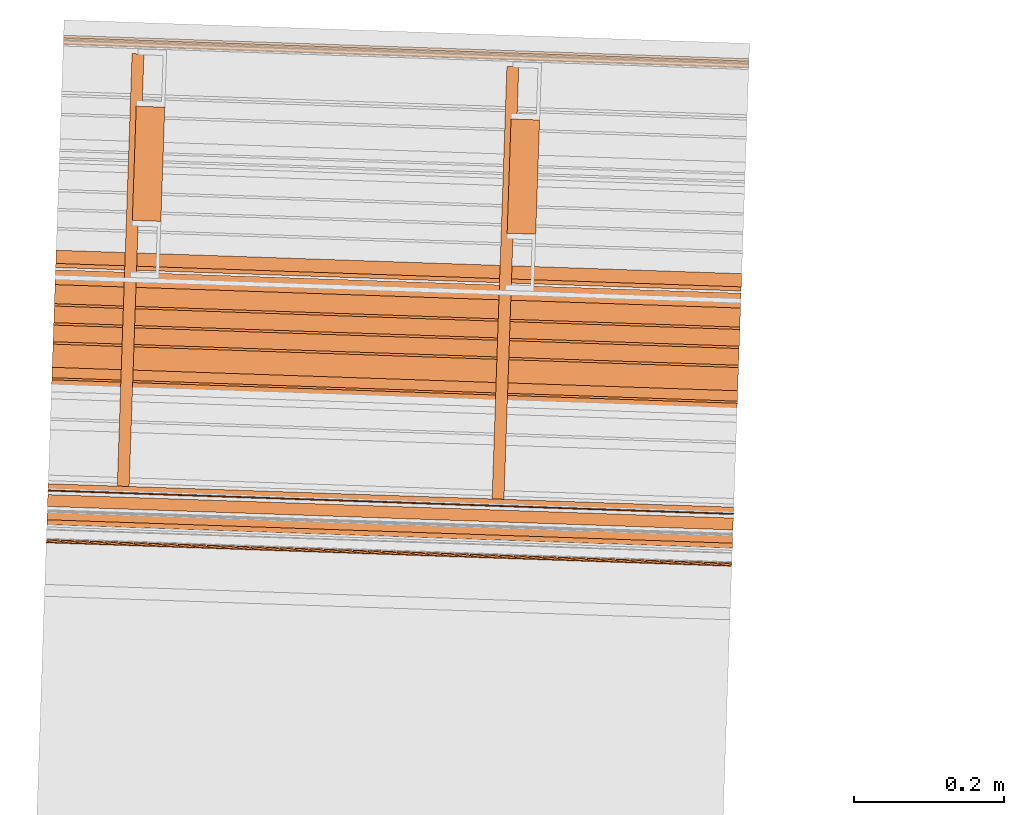
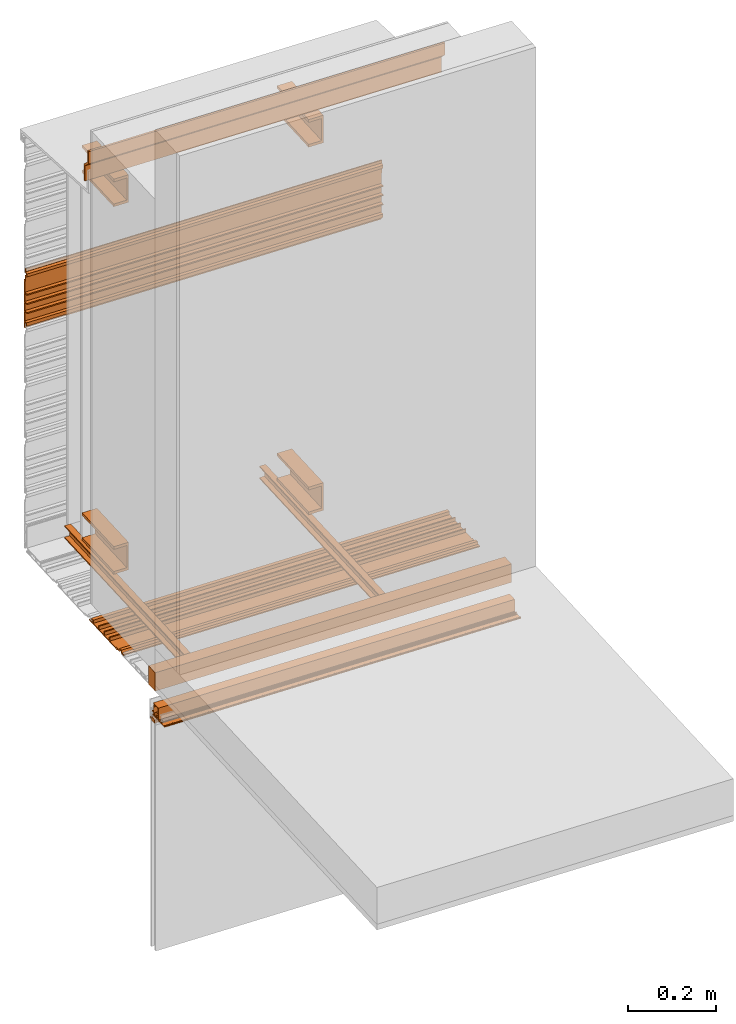
# One storey, part 4 of 7: 13 proxies.
"""IFC2X3 building model written with IfcOpenShell, lengths in feet."""

from ifc_helpers import new_model, entity, si_unit, converted_unit, derived_unit, direction, frame, frame_2d, origin, place, context, subcontext, project, spatial, polyline, circle_curve, parameter, trimmed, segment, composite_curve, rectangle, outline, extrude, source, transform, mapped, material, type_object, type_shapes, element, save


model = new_model("IFC2X3")

# Units and contexts
model_context = context("Model", 3, precision=0.0001, world=origin(), true_north=direction((6.12303176911189e-17, 1.0)))
context_of_model = context(None, 3, precision=0.0001, world=origin(), true_north=direction((6.12303176911189e-17, 1.0)))
body_context = subcontext(model_context, "Body", "Model", "MODEL_VIEW")
ifc_project = project(units=[converted_unit("LENGTHUNIT", "FOOT", entity("IfcRatioMeasure", 0.3048), si_unit("LENGTHUNIT", "METRE"), dimensions=[1, 0, 0, 0, 0, 0, 0]), converted_unit("AREAUNIT", "SQUARE FOOT", entity("IfcRatioMeasure", 0.09290304), si_unit("AREAUNIT", "SQUARE_METRE"), dimensions=[2, 0, 0, 0, 0, 0, 0]), converted_unit("VOLUMEUNIT", "CUBIC FOOT", entity("IfcRatioMeasure", 0.028316846592), si_unit("VOLUMEUNIT", "CUBIC_METRE"), dimensions=[3, 0, 0, 0, 0, 0, 0]), converted_unit("PLANEANGLEUNIT", "DEGREE", entity("IfcRatioMeasure", 0.0174532925199433), si_unit("PLANEANGLEUNIT", "RADIAN"), dimensions=[0, 0, 0, 0, 0, 0, 0]), si_unit("MASSUNIT", "GRAM", prefix="KILO"), derived_unit("MASSDENSITYUNIT", [(si_unit("MASSUNIT", "GRAM", prefix="KILO"), 1), (si_unit("LENGTHUNIT", "METRE"), -3)]), si_unit("TIMEUNIT", "SECOND"), si_unit("FREQUENCYUNIT", "HERTZ"), si_unit("THERMODYNAMICTEMPERATUREUNIT", "DEGREE_CELSIUS"), derived_unit("THERMALTRANSMITTANCEUNIT", [(si_unit("MASSUNIT", "GRAM", prefix="KILO"), 1), (si_unit("THERMODYNAMICTEMPERATUREUNIT", "KELVIN"), -1), (si_unit("TIMEUNIT", "SECOND"), -3)]), derived_unit("VOLUMETRICFLOWRATEUNIT", [(si_unit("LENGTHUNIT", "METRE"), 3), (si_unit("TIMEUNIT", "SECOND"), -1)]), si_unit("ELECTRICCURRENTUNIT", "AMPERE"), si_unit("ELECTRICVOLTAGEUNIT", "VOLT"), si_unit("POWERUNIT", "WATT"), si_unit("FORCEUNIT", "NEWTON"), si_unit("ILLUMINANCEUNIT", "LUX"), si_unit("LUMINOUSFLUXUNIT", "LUMEN"), si_unit("LUMINOUSINTENSITYUNIT", "CANDELA"), derived_unit("USERDEFINED", [(si_unit("MASSUNIT", "GRAM", prefix="KILO"), -1), (si_unit("LENGTHUNIT", "METRE"), -2), (si_unit("TIMEUNIT", "SECOND"), 3), (si_unit("LUMINOUSFLUXUNIT", "LUMEN"), 1)]), derived_unit("LINEARVELOCITYUNIT", [(si_unit("LENGTHUNIT", "METRE"), 1), (si_unit("TIMEUNIT", "SECOND"), -1)]), si_unit("PRESSUREUNIT", "PASCAL"), derived_unit("USERDEFINED", [(si_unit("LENGTHUNIT", "METRE"), -2), (si_unit("MASSUNIT", "GRAM", prefix="KILO"), 1), (si_unit("TIMEUNIT", "SECOND"), -2)])], contexts=[model_context, context_of_model])

# Site, building, storey
site_placement = place(None, origin())
site = spatial("IfcSite", under=ifc_project, at=site_placement, CompositionType="ELEMENT")
building_placement = place(site_placement, origin())
building = spatial("IfcBuilding", under=site, at=building_placement, CompositionType="ELEMENT")
storey_placement = place(building_placement, origin())
storey = spatial("IfcBuildingStorey", under=building, at=storey_placement, Name="Level 1", CompositionType="ELEMENT", Elevation=0.0)

# Proxies
ifc_material_1 = material(Name="IfcSurfaceStyle #179")
building_element_proxy_type_1 = type_object("IfcBuildingElementProxyType", Name="Metal support for window frame001", PredefinedType="NOTDEFINED", material=ifc_material_1)
shared_shape_1 = source(origin(), body_context, "Body", "SweptSolid", [
    extrude(rectangle(XDim=3.0, YDim=0.107278015091847, at=frame_2d((-6.99440505513849e-15, -2.42861286636753e-16), x_axis=(1.0, 0.0))), frame((111.216846057744, -50.6154050021282, 9.70833333333332), z_axis=(0.0, 0.0, 1.0), x_axis=(-0.999414947916634, 0.0342017818364937, 0.0)), (0.0, 0.0, 1.0), 0.166666666666668),
])
type_shapes(building_element_proxy_type_1, [shared_shape_1])
proxy_1_placement = place(storey_placement, origin())
element("IfcBuildingElementProxy", 1, at=proxy_1_placement, inside=storey, type_object=building_element_proxy_type_1, material=ifc_material_1, ObjectType="Metal support for window frame001", context=body_context, shape_type="MappedRepresentation", body=[
    mapped(shared_shape_1, transform((0.0, 0.0, 0.0), scale=1.0)),
])
ifc_material_2 = material(Name="LIGHT GAUGE METAL STUDS AND/OR FURRING")
building_element_proxy_type_2 = type_object("IfcBuildingElementProxyType", Name="Stud 004", PredefinedType="NOTDEFINED", material=ifc_material_2)
shared_shape_2 = source(origin(), body_context, "Body", "SweptSolid", [
    extrude(outline(polyline([(-0.0286458333333562, -0.0572916666666679), (0.0234374999999827, -0.0572916666666679), (0.0234374999999827, -0.046875), (-0.0182291666666801, -0.046875), (-0.0182291666666801, 0.046875), (0.0234374999999827, 0.046875), (0.0234374999999827, 0.0572916666666661), (-0.0286458333333562, 0.0572916666666661), (-0.0286458333333562, -0.0572916666666679)])), frame((110.044847585689, -50.5216266933335, 9.81770833333333), z_axis=(0.0342017818365511, 0.999414947916632, 0.0), x_axis=(-0.999414947916632, 0.0342017818365511, 0.0)), (0.0, 0.0, 1.0), 1.89272198512796),
])
type_shapes(building_element_proxy_type_2, [shared_shape_2])
proxy_2_placement = place(storey_placement, origin())
element("IfcBuildingElementProxy", 2, at=proxy_2_placement, inside=storey, type_object=building_element_proxy_type_2, material=ifc_material_2, Name="Stud 004:Stud 004", ObjectType="Stud 004", context=body_context, shape_type="MappedRepresentation", body=[
    mapped(shared_shape_2, transform((0.0, 0.0, 0.0), scale=1.0)),
])
building_element_proxy_type_3 = type_object("IfcBuildingElementProxyType", Name="Stud 003", PredefinedType="NOTDEFINED", material=ifc_material_2)
shared_shape_3 = source(origin(), body_context, "Body", "SweptSolid", [
    extrude(outline(polyline([(-0.0286458333333278, -0.0572916666666679), (0.023437500000025, -0.0572916666666679), (0.023437500000025, -0.046875), (-0.0182291666666514, -0.046875), (-0.0182291666666514, 0.046875), (0.023437500000025, 0.046875), (0.023437500000025, 0.0572916666666661), (-0.0286458333333278, 0.0572916666666661), (-0.0286458333333278, -0.0572916666666679)])), frame((111.684307802088, -50.5777319784982, 9.81770833333333), z_axis=(0.0342017818364056, 0.999414947916637, 0.0), x_axis=(-0.999414947916637, 0.0342017818364056, 0.0)), (0.0, 0.0, 1.0), 1.89272198512795),
])
type_shapes(building_element_proxy_type_3, [shared_shape_3])
proxy_3_placement = place(storey_placement, origin())
element("IfcBuildingElementProxy", 3, at=proxy_3_placement, inside=storey, type_object=building_element_proxy_type_3, material=ifc_material_2, Name="Stud 003:Stud 003", ObjectType="Stud 003", context=body_context, shape_type="MappedRepresentation", body=[
    mapped(shared_shape_3, transform((0.0, 0.0, 0.0), scale=1.0)),
])
ifc_material_3 = material(Name="METAL STUDS")
building_element_proxy_type_4 = type_object("IfcBuildingElementProxyType", Name="Metal stud 014", PredefinedType="NOTDEFINED", material=ifc_material_3)
shared_shape_4 = source(origin(), body_context, "Body", "SweptSolid", [
    extrude(outline(polyline([(-0.0661909448818519, -0.125), (0.0588090551181219, -0.125), (0.0588090551181219, -0.100393700787402), (-0.0514271653543063, -0.100393700787402), (-0.0514271653543063, 0.100393700787404), (0.0588090551181219, 0.100393700787404), (0.0588090551181219, 0.125000000000002), (-0.0661909448818519, 0.125000000000002), (-0.0661909448818519, -0.125)])), frame((110.146020542697, -49.3608525569486, 10.0), z_axis=(0.0342017818366075, 0.99941494791663, 0.0), x_axis=(-0.99941494791663, 0.0342017818366075, 0.0)), (0.0, 0.0, 1.0), 0.500000000000002),
])
type_shapes(building_element_proxy_type_4, [shared_shape_4])
proxy_4_placement = place(storey_placement, origin())
element("IfcBuildingElementProxy", 4, at=proxy_4_placement, inside=storey, type_object=building_element_proxy_type_4, material=ifc_material_3, Name="Metal stud 014:Metal stud 014", ObjectType="Metal stud 014", context=body_context, shape_type="MappedRepresentation", body=[
    mapped(shared_shape_4, transform((0.0, 0.0, 0.0), scale=1.0)),
])
building_element_proxy_type_5 = type_object("IfcBuildingElementProxyType", Name="Metal stud 011", PredefinedType="NOTDEFINED", material=ifc_material_3)
shared_shape_5 = source(origin(), body_context, "Body", "SweptSolid", [
    extrude(outline(polyline([(-0.0661909448818519, -0.125), (0.0588090551181219, -0.125), (0.0588090551181219, -0.1003937007874), (-0.0514271653543063, -0.1003937007874), (-0.0514271653543063, 0.1003937007874), (0.0588090551181219, 0.1003937007874), (0.0588090551181219, 0.125), (-0.0661909448818519, 0.125), (-0.0661909448818519, -0.125)])), frame((110.146020542697, -49.3608525569486, 13.3333333333333), z_axis=(0.0342017818366075, 0.99941494791663, 0.0), x_axis=(-0.99941494791663, 0.0342017818366075, 0.0)), (0.0, 0.0, 1.0), 0.500000000000002),
])
type_shapes(building_element_proxy_type_5, [shared_shape_5])
proxy_5_placement = place(storey_placement, origin())
element("IfcBuildingElementProxy", 5, at=proxy_5_placement, inside=storey, type_object=building_element_proxy_type_5, material=ifc_material_3, Name="Metal stud 011:Metal stud 011", ObjectType="Metal stud 011", context=body_context, shape_type="MappedRepresentation", body=[
    mapped(shared_shape_5, transform((0.0, 0.0, 0.0), scale=1.0)),
])
building_element_proxy_type_6 = type_object("IfcBuildingElementProxyType", Name="Metal stud 013", PredefinedType="NOTDEFINED", material=ifc_material_3)
shared_shape_6 = source(origin(), body_context, "Body", "SweptSolid", [
    extrude(outline(polyline([(-0.0661909448818803, -0.125), (0.0588090551181075, -0.125), (0.0588090551181075, -0.1003937007874), (-0.0514271653543347, -0.1003937007874), (-0.0514271653543347, 0.1003937007874), (0.0588090551181075, 0.1003937007874), (0.0588090551181075, 0.125), (-0.0661909448818803, 0.125), (-0.0661909448818803, -0.125)])), frame((111.785480759096, -49.4169578421136, 13.3333333333333), z_axis=(0.0342017818365468, 0.999414947916633, 0.0), x_axis=(-0.999414947916633, 0.0342017818365468, 0.0)), (0.0, 0.0, 1.0), 0.500000000000001),
])
type_shapes(building_element_proxy_type_6, [shared_shape_6])
proxy_6_placement = place(storey_placement, origin())
element("IfcBuildingElementProxy", 6, at=proxy_6_placement, inside=storey, type_object=building_element_proxy_type_6, material=ifc_material_3, Name="Metal stud 013:Metal stud 013", ObjectType="Metal stud 013", context=body_context, shape_type="MappedRepresentation", body=[
    mapped(shared_shape_6, transform((0.0, 0.0, 0.0), scale=1.0)),
])
building_element_proxy_type_7 = type_object("IfcBuildingElementProxyType", Name="Metal stud 012", PredefinedType="NOTDEFINED", material=ifc_material_3)
shared_shape_7 = source(origin(), body_context, "Body", "SweptSolid", [
    extrude(outline(polyline([(-0.0661909448818803, -0.125), (0.0588090551181075, -0.125), (0.0588090551181075, -0.100393700787402), (-0.0514271653543347, -0.100393700787402), (-0.0514271653543347, 0.100393700787404), (0.0588090551181075, 0.100393700787404), (0.0588090551181075, 0.125000000000002), (-0.0661909448818803, 0.125000000000002), (-0.0661909448818803, -0.125)])), frame((111.785480759096, -49.4169578421136, 10.0), z_axis=(0.0342017818365468, 0.999414947916633, 0.0), x_axis=(-0.999414947916633, 0.0342017818365468, 0.0)), (0.0, 0.0, 1.0), 0.500000000000001),
])
type_shapes(building_element_proxy_type_7, [shared_shape_7])
proxy_7_placement = place(storey_placement, origin())
element("IfcBuildingElementProxy", 7, at=proxy_7_placement, inside=storey, type_object=building_element_proxy_type_7, material=ifc_material_3, Name="Metal stud 012:Metal stud 012", ObjectType="Metal stud 012", context=body_context, shape_type="MappedRepresentation", body=[
    mapped(shared_shape_7, transform((0.0, 0.0, 0.0), scale=1.0)),
])
ifc_material_4 = material()
building_element_proxy_type_8 = type_object("IfcBuildingElementProxyType", Name="Flashing 003", PredefinedType="NOTDEFINED", material=ifc_material_4)
shared_shape_8 = source(origin(), body_context, "Body", "SweptSolid", [
    extrude(outline(polyline([(-0.0371589137820224, 0.0154669259900354), (-0.135772181632417, -0.0923404467542823), (-0.122552267089255, -0.104432931160668), (-0.0292661571907254, -0.00244938836847988), (0.0490662805214159, -0.0024493883946275), (0.123864814921589, 0.0793229091327372), (0.110644900349842, 0.0914153935652706), (0.0411735239015335, 0.0154669259900354), (-0.0371589137820224, 0.0154669259900354)])), frame((109.753215664138, -49.5269849138619, 13.807758480938), z_axis=(-0.999414947916625, 0.0342017818367569, 0.0), x_axis=(-0.025236475786405, -0.737438512825177, 0.674942634667624)), (0.0, 0.0, -1.0), 3.0),
])
type_shapes(building_element_proxy_type_8, [shared_shape_8])
proxy_8_placement = place(storey_placement, origin())
element("IfcBuildingElementProxy", 8, at=proxy_8_placement, inside=storey, type_object=building_element_proxy_type_8, material=ifc_material_4, Name="Flashing 003:Flashing 003", ObjectType="Flashing 003", context=body_context, shape_type="MappedRepresentation", body=[
    mapped(shared_shape_8, transform((0.0, 0.0, 0.0), scale=1.0)),
])
ifc_material_5 = material(Name="Window frame")
building_element_proxy_type_9 = type_object("IfcBuildingElementProxyType", Name="Window frame 017", PredefinedType="NOTDEFINED", material=ifc_material_5)
shared_shape_9 = source(origin(), body_context, "Body", "SweptSolid", [
    extrude(outline(composite_curve([segment(polyline([(-0.0145833333334195, -0.0259583333333165), (0.0145833333334213, -0.0259583333333165)]), True, "CONTINUOUS"), segment(trimmed(circle_curve(frame_2d((-0.118933680555463, 0.0), x_axis=(0.0, -1.0)), 0.13601701388888), [parameter(78.9978270971977)], [parameter(101.002172902812)], True, "PARAMETER"), True, "CONTINUOUS"), segment(polyline([(0.0145833333334178, 0.0259583333333232), (-0.014583333333416, 0.0259583333333232)]), True, "CONTINUOUS"), segment(trimmed(circle_curve(frame_2d((0.118933680555465, 0.0), x_axis=(0.0, -1.0)), 0.13601701388888), [parameter(258.997827097188)], [parameter(281.002172902802)], True, "PARAMETER"), True, "CONTINUOUS")], self_intersect=False)), frame((109.717039781299, -50.5840853372173, 9.42538449904838), z_axis=(0.999414947916641, -0.0342017818362893, 0.0), x_axis=(0.0, 0.0, -1.0)), (0.0, 0.0, 1.0), 3.0),
])
type_shapes(building_element_proxy_type_9, [shared_shape_9])
proxy_9_placement = place(storey_placement, origin())
element("IfcBuildingElementProxy", 9, at=proxy_9_placement, inside=storey, type_object=building_element_proxy_type_9, material=ifc_material_5, Name="Window frame 017:Window frame 017", ObjectType="Window frame 017", context=body_context, shape_type="MappedRepresentation", body=[
    mapped(shared_shape_9, transform((0.0, 0.0, 0.0), scale=1.0)),
])
building_element_proxy_type_10 = type_object("IfcBuildingElementProxyType", Name="Window frame 014", PredefinedType="NOTDEFINED", material=ifc_material_5)
shared_shape_10 = source(origin(), body_context, "Body", "SweptSolid", [
    extrude(rectangle(XDim=3.0, YDim=0.00499999999997292, at=frame_2d((6.99440505513849e-15, 3.7921055184853e-15), x_axis=(1.0, 0.0))), frame((111.217669931724, -50.5913304676835, 9.4124678323819), z_axis=(0.0, 0.0, 1.0), x_axis=(-0.999414947916663, 0.0342017818356482, 0.0)), (0.0, 0.0, 1.0), 0.0208333333333339),
])
type_shapes(building_element_proxy_type_10, [shared_shape_10])
proxy_10_placement = place(storey_placement, origin())
element("IfcBuildingElementProxy", 10, at=proxy_10_placement, inside=storey, type_object=building_element_proxy_type_10, material=ifc_material_5, Name="Window frame 014:Window frame 014", ObjectType="Window frame 014", context=body_context, shape_type="MappedRepresentation", body=[
    mapped(shared_shape_10, transform((0.0, 0.0, 0.0), scale=1.0)),
])
ifc_material_6 = material()
building_element_proxy_type_11 = type_object("IfcBuildingElementProxyType", Name="panel 021", PredefinedType="NOTDEFINED", material=ifc_material_6)
shared_shape_11 = source(origin(), body_context, "Body", "SweptSolid", [
    extrude(outline(polyline([(-0.0220175316851953, 0.145680147068472), (-0.0220175316851953, -0.291819852931525), (-0.0116008650185187, -0.291819852931525), (-0.0116008650185187, -0.237132352931535), (0.00451787028331154, -0.237132352931535), (0.00451787028331154, -0.257965686264864), (0.0173047730392253, -0.257965686264864), (0.0173047730392253, -0.226715686264859), (-0.0116008650185187, -0.226715686264859), (-0.0116008650185187, -0.143382352931519), (0.0196491349814752, -0.143382352931519), (0.0196491349814752, -0.132965686264868), (-0.0116008650185187, -0.132965686264868), (-0.0116008650185187, -0.060049019598182), (0.0196491349814752, -0.060049019598182), (0.0196491349814752, -0.0496323529315283), (-0.0116008650185187, -0.0496323529315283), (-0.0116008650185187, 0.0232843137351324), (0.0196491349814752, 0.0232843137351324), (0.0196491349814752, 0.0337009804018091), (-0.0116008650185187, 0.0337009804018091), (-0.0116008650185187, 0.135263480401818), (-0.00118419835184916, 0.135263480401818), (-0.00118419835184916, 0.1807106651131), (0.0186287630982651, 0.18994960080863), (0.0186287630982651, 0.215994026661653), (-0.00118419835184916, 0.225232962029098), (-0.00118419835184916, 0.249846813735138), (-0.0116008650185187, 0.249846813735138), (-0.0116008650185187, 0.218596813735132), (0.0061931721533835, 0.210299318000235), (0.0061931721533835, 0.195644309470049), (-0.0116008650185187, 0.187346813735152), (-0.0116008650185187, 0.145680147068472), (-0.0220175316851953, 0.145680147068472)])), frame((109.785926286855, -48.5711433305344, 12.021009163627), z_axis=(-0.999414947916601, 0.034201781837477, 0.0), x_axis=(-0.034201781837477, -0.999414947916601, 0.0)), (0.0, 0.0, -1.0), 3.0),
])
type_shapes(building_element_proxy_type_11, [shared_shape_11])
proxy_11_placement = place(storey_placement, origin())
element("IfcBuildingElementProxy", 11, at=proxy_11_placement, inside=storey, type_object=building_element_proxy_type_11, material=ifc_material_6, Name="panel 021:panel 021", ObjectType="panel 021", context=body_context, shape_type="MappedRepresentation", body=[
    mapped(shared_shape_11, transform((0.0, 0.0, 0.0), scale=1.0)),
])
building_element_proxy_type_12 = type_object("IfcBuildingElementProxyType", Name="panel 018", PredefinedType="NOTDEFINED", material=ifc_material_6)
shared_shape_12 = source(origin(), body_context, "Body", "SweptSolid", [
    extrude(outline(polyline([(-0.291819852941177, -0.011600865003091), (-0.291819852941177, -0.0220175316697446), (0.145680147058845, -0.0220175316697446), (0.145680147058845, -0.011600865003091), (0.187346813725486, -0.011600865003091), (0.195644309526018, 0.00619317207041981), (0.210299317924977, 0.00619317207041981), (0.218596813725508, -0.011600865003091), (0.24984681372553, -0.011600865003091), (0.24984681372553, -0.00118419833641603), (0.225232962281936, -0.00118419833641603), (0.215994026619204, 0.0186287629496675), (0.189949600831819, 0.0186287629496675), (0.18071066516908, -0.00118419833641603), (0.135263480392169, -0.00118419833641603), (0.135263480392169, -0.011600865003091), (0.0337009803921564, -0.011600865003091), (0.0337009803921564, 0.0196491349969126), (0.0232843137255086, 0.0196491349969126), (0.0232843137255086, -0.011600865003091), (-0.0496323529411549, -0.011600865003091), (-0.0496323529411549, 0.0196491349969126), (-0.0600490196078311, 0.0196491349969126), (-0.0600490196078311, -0.011600865003091), (-0.132965686274494, -0.011600865003091), (-0.132965686274494, 0.0196491349969126), (-0.143382352941171, 0.0196491349969126), (-0.143382352941171, -0.011600865003091), (-0.22671568627451, -0.011600865003091), (-0.22671568627451, 0.0173047731202818), (-0.257965686274482, 0.0173047731202818), (-0.257965686274482, 0.00451787023313344), (-0.237132352941158, 0.00451787023313344), (-0.237132352941158, -0.011600865003091), (-0.291819852941177, -0.011600865003091)])), frame((109.741606113486, -49.8662291822323, 9.73037350903191), z_axis=(-0.999414947916631, 0.0342017818365886, 0.0), x_axis=(-0.0342017818365886, -0.999414947916631, 0.0)), (0.0, 0.0, -1.0), 2.99999999999999),
])
type_shapes(building_element_proxy_type_12, [shared_shape_12])
proxy_12_placement = place(storey_placement, origin())
element("IfcBuildingElementProxy", 12, at=proxy_12_placement, inside=storey, type_object=building_element_proxy_type_12, material=ifc_material_6, Name="panel 018:panel 018", ObjectType="panel 018", context=body_context, shape_type="MappedRepresentation", body=[
    mapped(shared_shape_12, transform((0.0, 0.0, 0.0), scale=1.0)),
])
building_element_proxy_type_13 = type_object("IfcBuildingElementProxyType", Name="Window frame 018", PredefinedType="NOTDEFINED", material=ifc_material_5)
shared_shape_13 = source(origin(), body_context, "Body", "SweptSolid", [
    extrude(outline(composite_curve([segment(polyline([(0.0675789518158966, 0.048977386743883), (0.0749254580971562, 0.048977386743883)]), True, "CONTINUOUS"), segment(polyline([(0.0749254580971562, 0.048977386743883), (0.0793909148601383, 0.0567117847363653)]), True, "CONTINUOUS"), segment(polyline([(0.0793909148601383, 0.0567117847363653), (0.00902635080266761, 0.0973367847363772)]), True, "CONTINUOUS"), segment(polyline([(0.00902635080266761, 0.0973367847363772), (-0.0449319825306894, 0.00387820991131866)]), True, "CONTINUOUS"), segment(polyline([(-0.0449319825306894, 0.00387820991131866), (-0.0631316453622747, 0.0143857901463002)]), True, "CONTINUOUS"), segment(trimmed(circle_curve(frame_2d((-0.0618399786956073, 0.0166230224394101), x_axis=(-0.50000000000022, -0.866025403784317)), 0.00258333333333319), [parameter(260.405931773143)], [parameter(1.42488849729566e-12)], True, "PARAMETER"), False, "CONTINUOUS"), segment(trimmed(circle_curve(frame_2d((-0.0718575086920618, 0.0249084972459709), x_axis=(0.770579230496494, -0.637344215889211)), 0.0104166666666668), [parameter(359.999999999995)], [parameter(99.5940682268605)], True, "PARAMETER"), True, "CONTINUOUS"), segment(polyline([(-0.0666491753587272, 0.0339295952020574), (-0.0687325086920612, 0.0303211560196229)]), True, "CONTINUOUS"), segment(trimmed(circle_curve(frame_2d((-0.0718575086920622, 0.0249084972459711), x_axis=(0.500000000000192, 0.866025403784331)), 0.00624999999999994), [parameter(90.0000000000001)], [parameter(0.0)], True, "PARAMETER"), False, "CONTINUOUS"), segment(polyline([(-0.0772701674657148, 0.0280334972459726), (-0.0808786066481457, 0.0301168305793046)]), True, "CONTINUOUS"), segment(polyline([(-0.0808786066481457, 0.0301168305793046), (-0.0832536066481473, 0.0260032099113278)]), True, "CONTINUOUS"), segment(polyline([(-0.0832536066481473, 0.0260032099113278), (-0.117267721978646, 0.045641268553648)]), True, "CONTINUOUS"), segment(trimmed(circle_curve(frame_2d((-0.115976055311978, 0.047878500846758), x_axis=(-0.50000000000027, -0.866025403784288)), 0.00258333333333344), [parameter(278.346619263229)], [parameter(4.93622086563138e-12)], True, "PARAMETER"), False, "CONTINUOUS"), segment(trimmed(circle_curve(frame_2d((-0.125580197468803, 0.05169140409877), x_axis=(0.929433111951099, -0.368990637291663)), 0.00775000000000006), [parameter(3.46044349343231e-12)], [parameter(261.653380736779)], True, "PARAMETER"), True, "CONTINUOUS"), segment(polyline([(-0.129455197468806, 0.0449797072194422), (-0.0349862596726644, -0.00956195944724552)]), True, "CONTINUOUS"), segment(polyline([(-0.0349862596726644, -0.00956195944724552), (-0.0279029263393282, 0.00270673377303185)]), True, "CONTINUOUS"), segment(polyline([(-0.0279029263393282, 0.00270673377303185), (-0.0174384527102663, -0.00333493289363782)]), True, "CONTINUOUS"), segment(polyline([(-0.0174384527102663, -0.00333493289363782), (-0.0232301193769347, -0.0133663938208055)]), True, "CONTINUOUS"), segment(trimmed(circle_curve(frame_2d((-0.0209928870838289, -0.0146580604874705), x_axis=(-0.866025403784334, 0.500000000000188)), 0.00258333333333323), [parameter(0.0)], [parameter(90.0000000000001)], True, "PARAMETER"), True, "CONTINUOUS"), segment(polyline([(-0.0222845537504963, -0.0168952927805805), (0.00645395181614466, -0.0334874767055965)]), True, "CONTINUOUS"), segment(polyline([(0.00645395181614466, -0.0334874767055965), (0.0122328795512514, -0.0301510112221009)]), True, "CONTINUOUS"), segment(trimmed(circle_curve(frame_2d((0.0175372851493896, -0.0270885112220285), x_axis=(-0.866025403777542, -0.500000000011955)), 0.00612500000000058), [parameter(60.0000000000108)], [parameter(359.999999999989)], True, "PARAMETER"), False, "CONTINUOUS"), segment(polyline([(0.0175372851494753, -0.0332135112220295), (0.0175372851494748, -0.0398864421891163)]), True, "CONTINUOUS"), segment(polyline([(0.0175372851494748, -0.0398864421891163), (0.0314090212841321, -0.0478952927805922)]), True, "CONTINUOUS"), segment(trimmed(circle_curve(frame_2d((0.0327006879507995, -0.0456580604874822), x_axis=(-0.500000000000192, -0.866025403784331)), 0.00258333333333323), [parameter(0.0)], [parameter(90.0000000000001)], True, "PARAMETER"), True, "CONTINUOUS"), segment(polyline([(0.0349379202439119, -0.0469497271541511), (0.0372712535772402, -0.0429082752698203)]), True, "CONTINUOUS"), segment(trimmed(circle_curve(frame_2d((0.0354670339860247, -0.0418666086031543), x_axis=(0.866025403784327, -0.500000000000188)), 0.00208333333333337), [parameter(0.0)], [parameter(180.0)], True, "PARAMETER"), True, "CONTINUOUS"), segment(trimmed(circle_curve(frame_2d((0.0318585948035929, -0.0397832752698239), x_axis=(0.866025403784484, -0.499999999999911)), 0.00208333333333285), [parameter(269.999999999982)], [parameter(3.05333249420498e-11)], True, "PARAMETER"), False, "CONTINUOUS"), segment(polyline([(0.0308169281369259, -0.0415874948610412), (0.0264868011180027, -0.0390874948610393)]), True, "CONTINUOUS"), segment(trimmed(circle_curve(frame_2d((0.0275284677846697, -0.0372832752698221), x_axis=(-0.500000000000227, -0.86602540378431)), 0.00208333333333329), [parameter(270.000000000002)], [parameter(2.03555499613665e-12)], True, "PARAMETER"), False, "CONTINUOUS"), segment(polyline([(0.0257242481934542, -0.0362416086031561), (0.0357138315267868, -0.0189391427233763)]), True, "CONTINUOUS"), segment(trimmed(circle_curve(frame_2d((0.0375180511180023, -0.0199808093900422), x_axis=(-0.866025403784299, 0.500000000000249)), 0.00208333333333366), [parameter(270.000000000004)], [parameter(4.07110999227331e-12)], True, "PARAMETER"), False, "CONTINUOUS"), segment(polyline([(0.0385597177846693, -0.018176589798825), (0.0428898448035925, -0.0206765897988268)]), True, "CONTINUOUS"), segment(trimmed(circle_curve(frame_2d((0.0418481781369255, -0.0224808093900441), x_axis=(0.500000000000306, 0.86602540378426)), 0.00208333333333351), [parameter(270.000000000008)], [parameter(8.14221998454661e-12)], True, "PARAMETER"), False, "CONTINUOUS"), segment(trimmed(circle_curve(frame_2d((0.0454566173193626, -0.0245641427233796), x_axis=(-0.866025403784334, 0.500000000000188)), 0.0020833333333338), [parameter(0.0)], [parameter(180.0)], True, "PARAMETER"), True, "CONTINUOUS"), segment(polyline([(0.0472608369105781, -0.0256058093900456), (0.0485629202439116, -0.0233505349010244)]), True, "CONTINUOUS"), segment(polyline([(0.0485629202439116, -0.0233505349010244), (0.050800152537024, -0.0246422015676932)]), True, "CONTINUOUS"), segment(polyline([(0.050800152537024, -0.0246422015676932), (0.0541334858703582, -0.0188686988757983)]), True, "CONTINUOUS"), segment(polyline([(0.0541334858703582, -0.0188686988757983), (0.040349248193455, -0.0109103655424604)]), True, "CONTINUOUS"), segment(polyline([(0.040349248193455, -0.0109103655424604), (0.0681897049565487, 0.0373107200771151)]), True, "CONTINUOUS"), segment(polyline([(0.0681897049565487, 0.0373107200771151), (0.0645164518159689, 0.0436729811456607)]), True, "CONTINUOUS"), segment(trimmed(circle_curve(frame_2d((0.0614539518158953, 0.0489773867437944), x_axis=(0.500000000012392, -0.866025403777282)), 0.00612500000000085), [parameter(60.000000000009)], [parameter(359.999999999962)], True, "PARAMETER"), False, "CONTINUOUS")], self_intersect=False), holes=[composite_curve([segment(trimmed(circle_curve(frame_2d((0.00340047720133191, -0.0210435723360201), x_axis=(0.919467183408578, -0.393166756777187)), 0.00258333333333322), [parameter(263.151688393523)], [parameter(1.60833780243498e-08)], True, "PARAMETER"), False, "CONTINUOUS"), segment(polyline([(0.00210881053781462, -0.0232808046296893), (-0.0154149500183786, -0.0131634567553515)]), True, "CONTINUOUS"), segment(polyline([(-0.0154149500183786, -0.0131634567553515), (-0.00833161668504148, -0.000894763535072612)]), True, "CONTINUOUS"), segment(polyline([(-0.00833161668504148, -0.000894763535072612), (-0.0320751465054564, 0.0128135697982628)]), True, "CONTINUOUS"), segment(polyline([(-0.0320751465054564, 0.0128135697982628), (0.0114665201612217, 0.0882299487111498)]), True, "CONTINUOUS"), segment(polyline([(0.0114665201612217, 0.0882299487111498), (0.0538538377496349, 0.063757619491241)]), True, "CONTINUOUS"), segment(trimmed(circle_curve(frame_2d((0.0525621710798178, 0.0615203871986901), x_axis=(0.500000000000178, 0.866025403784338)), 0.00258333333333334), [parameter(245.332972808387)], [parameter(359.999999933301)], True, "PARAMETER"), False, "CONTINUOUS"), segment(trimmed(circle_curve(frame_2d((0.0614539518127466, 0.048977386744357), x_axis=(-0.578327202141878, 0.81580490759908)), 0.0127916666666671), [parameter(359.999999989932)], [parameter(123.710369504572)], True, "PARAMETER"), True, "CONTINUOUS"), segment(trimmed(circle_curve(frame_2d((0.0559549043098467, 0.0346194237425621), x_axis=(0.357661626205186, 0.933851252149005)), 0.00258333333333383), [parameter(260.956657775149)], [parameter(359.99999993039)], True, "PARAMETER"), False, "CONTINUOUS"), segment(polyline([(0.0581921366061088, 0.0333277570753342), (0.0294593543970394, -0.0164388815535428)]), True, "CONTINUOUS"), segment(trimmed(circle_curve(frame_2d((0.0272221221007839, -0.0151472148863187), x_axis=(0.866025403784384, -0.500000000000089)), 0.00258333333333374), [parameter(260.956657813753)], [parameter(2.41835129093513e-08)], True, "PARAMETER"), False, "CONTINUOUS"), segment(trimmed(circle_curve(frame_2d((0.0175372851462404, -0.0270885112214697), x_axis=(0.629908094604453, 0.776669680335075)), 0.0127916666666673), [parameter(359.99999998747)], [parameter(105.891653918215)], True, "PARAMETER"), True, "CONTINUOUS")], self_intersect=False)]), frame((109.715561170206, -50.6272920343482, 9.49657519548266), z_axis=(0.999414947916607, -0.034201781837303, 0.0), x_axis=(0.0296196119265885, 0.865518733817546, 0.50000000000019)), (0.0, 0.0, 1.0), 2.99999999999999),
])
type_shapes(building_element_proxy_type_13, [shared_shape_13])
proxy_13_placement = place(storey_placement, origin())
element("IfcBuildingElementProxy", 13, at=proxy_13_placement, inside=storey, type_object=building_element_proxy_type_13, material=ifc_material_5, Name="Window frame 1:Window frame 018", ObjectType="Window frame 018", context=body_context, shape_type="MappedRepresentation", body=[
    mapped(shared_shape_13, transform((0.0, 0.0, 0.0), scale=1.0)),
])

save(model, "model.ifc")
